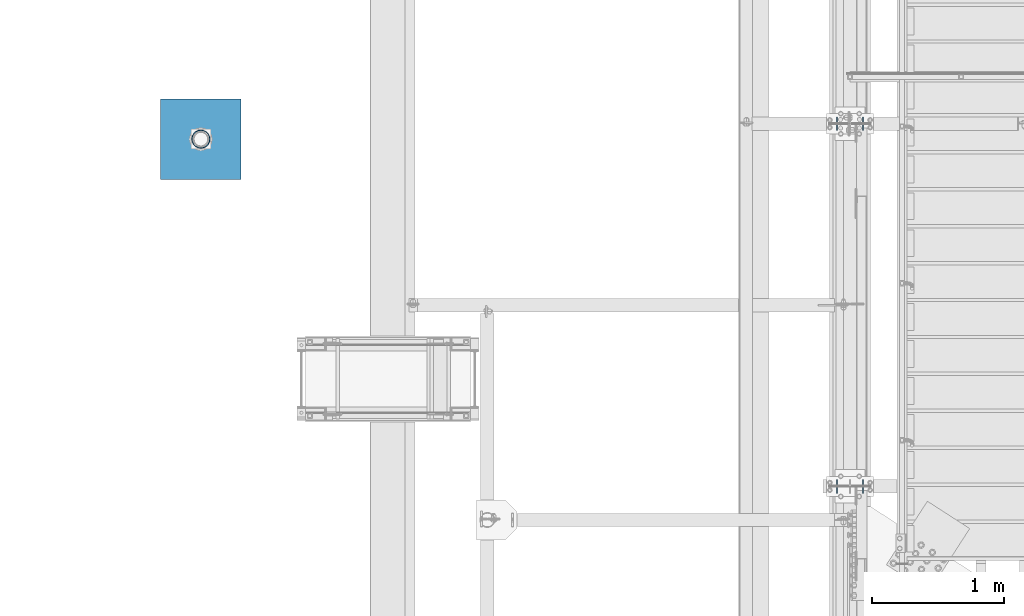
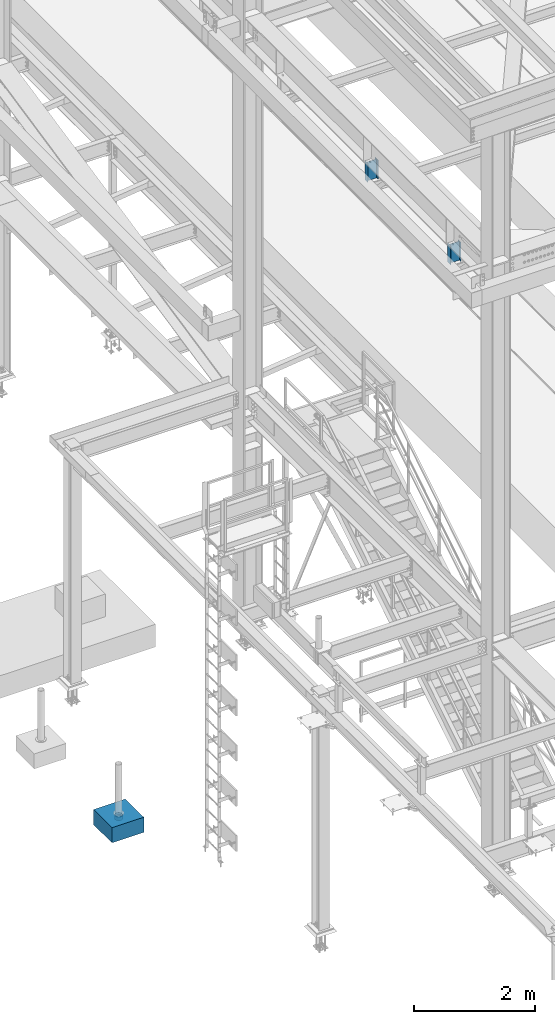
# One storey, part 1456 of 3843: 4 columns, 4 elements without a shape of their own.
"""IFC2X3 building model written with IfcOpenShell, lengths in millimetres."""

from ifc_helpers import new_model, si_unit, frame, origin_with_axes, place, context, subcontext, project, spatial, faceted_brep, material, type_object, element, aggregate, save


model = new_model("IFC2X3")

# Units and contexts
model_context = context("Model", 3, precision=1e-05, world=origin_with_axes())
body_context = subcontext(model_context, "Body", "Model", "MODEL_VIEW")
ifc_project = project(units=[si_unit("LENGTHUNIT", "METRE", prefix="MILLI"), si_unit("AREAUNIT", "SQUARE_METRE"), si_unit("VOLUMEUNIT", "CUBIC_METRE"), si_unit("MASSUNIT", "GRAM", prefix="KILO"), si_unit("TIMEUNIT", "SECOND"), si_unit("PLANEANGLEUNIT", "RADIAN"), si_unit("SOLIDANGLEUNIT", "STERADIAN"), si_unit("THERMODYNAMICTEMPERATUREUNIT", "DEGREE_CELSIUS"), si_unit("LUMINOUSINTENSITYUNIT", "LUMEN")], contexts=[model_context])

# Site, building, storey
site_placement = place(None, origin_with_axes())
site = spatial("IfcSite", under=ifc_project, at=site_placement, CompositionType="ELEMENT")
building_placement = place(site_placement, origin_with_axes())
building = spatial("IfcBuilding", under=site, at=building_placement, Name="Undefined", CompositionType="ELEMENT")
storey_placement = place(building_placement, origin_with_axes())
storey = spatial("IfcBuildingStorey", under=building, at=storey_placement, Name="Undefined", CompositionType="ELEMENT", Elevation=0.0)

# Assembly, column
assembly_1_placement = place(storey_placement, origin_with_axes())
assembly_1 = element("IfcElementAssembly", 1, at=assembly_1_placement, inside=storey, Name="PLATE", AssemblyPlace="NOTDEFINED", PredefinedType="RIGID_FRAME")
ifc_material_1 = material()
column_type_1 = type_object("IfcColumnType", Name="PIPE5SCH40", PredefinedType="NOTDEFINED")
column_1_placement = place(assembly_1_placement, frame((31665.2636373341, 29614.5098879337, 30378.4), z_axis=(-1.0, 0.0, 0.0), x_axis=(0.0, 0.0, 1.0)))
column_1 = element("IfcColumn", 2, at=column_1_placement, type_object=column_type_1, material=ifc_material_1, Name="PIPE_SLEEVE", ObjectType="PIPE5SCH40", context=body_context, shape_type="Brep", body=[
    faceted_brep([(0.0, -64.0587999999998, 0.0), (0.0, -60.9235391660477, 19.7952578392724), (76.2000000000007, -60.9235391660477, 19.7952578392724), (76.2000000000007, -64.0587999999998, 0.0), (0.0, -51.8246578392655, 37.6528179195593), (76.2000000000007, -51.8246578392655, 37.6528179195593), (0.0, -37.6528179195529, 51.8246578392718), (76.2000000000007, -37.6528179195529, 51.8246578392718), (0.0, -19.795257839266, 60.9235391660477), (76.2000000000007, -19.795257839266, 60.9235391660477), (0.0, 0.0, 64.0587999999989), (76.2000000000007, 0.0, 64.0587999999989), (0.0, 19.795257839266, 60.9235391660477), (76.2000000000007, 19.795257839266, 60.9235391660477), (0.0, 37.6528179195529, 51.8246578392718), (76.2000000000007, 37.6528179195529, 51.8246578392718), (0.0, 51.8246578392655, 37.6528179195593), (76.2000000000007, 51.8246578392655, 37.6528179195593), (0.0, 60.9235391660477, 19.7952578392724), (76.2000000000007, 60.9235391660477, 19.7952578392724), (0.0, 64.0587999999998, 0.0), (76.2000000000007, 64.0587999999998, 0.0), (0.0, 60.9235391660477, -19.7952578392724), (76.2000000000007, 60.9235391660477, -19.7952578392724), (0.0, 51.8246578392655, -37.6528179195593), (76.2000000000007, 51.8246578392655, -37.6528179195593), (0.0, 37.6528179195529, -51.8246578392718), (76.2000000000007, 37.6528179195529, -51.8246578392718), (0.0, 19.795257839266, -60.9235391660477), (76.2000000000007, 19.795257839266, -60.9235391660477), (0.0, 0.0, -64.0587999999989), (76.2000000000007, 0.0, -64.0587999999989), (0.0, -19.795257839266, -60.9235391660477), (76.2000000000007, -19.795257839266, -60.9235391660477), (0.0, -37.6528179195529, -51.8246578392718), (76.2000000000007, -37.6528179195529, -51.8246578392718), (0.0, -51.8246578392655, -37.6528179195593), (76.2000000000007, -51.8246578392655, -37.6528179195593), (0.0, -60.9235391660477, -19.7952578392724), (76.2000000000007, -60.9235391660477, -19.7952578392724), (0.0, -70.6120000000001, 0.0), (0.0, -67.1560027286332, -21.8203080068051), (76.2000000000007, -67.1560027286332, -21.8203080068051), (76.2000000000007, -70.6120000000001, 0.0), (0.0, -57.1263080068038, -41.5046922348702), (76.2000000000007, -57.1263080068038, -41.5046922348702), (0.0, -41.5046922348765, -57.126308006802), (76.2000000000007, -41.5046922348765, -57.126308006802), (0.0, -21.8203080068042, -67.1560027286323), (76.2000000000007, -21.8203080068042, -67.1560027286323), (0.0, 0.0, -70.6119999999937), (76.2000000000007, 0.0, -70.6119999999937), (0.0, 21.8203080068042, -67.1560027286323), (76.2000000000007, 21.8203080068042, -67.1560027286323), (0.0, 41.5046922348765, -57.126308006802), (76.2000000000007, 41.5046922348765, -57.126308006802), (0.0, 57.1263080068038, -41.5046922348702), (76.2000000000007, 57.1263080068038, -41.5046922348702), (0.0, 67.1560027286332, -21.8203080068051), (76.2000000000007, 67.1560027286332, -21.8203080068051), (0.0, 70.6120000000001, 0.0), (76.2000000000007, 70.6120000000001, 0.0), (0.0, 67.1560027286332, 21.8203080068051), (76.2000000000007, 67.1560027286332, 21.8203080068051), (0.0, 57.1263080068038, 41.5046922348702), (76.2000000000007, 57.1263080068038, 41.5046922348702), (0.0, 41.5046922348765, 57.126308006802), (76.2000000000007, 41.5046922348765, 57.126308006802), (0.0, 21.8203080068042, 67.1560027286323), (76.2000000000007, 21.8203080068042, 67.1560027286323), (0.0, 0.0, 70.6119999999937), (76.2000000000007, 0.0, 70.6119999999937), (0.0, -21.8203080068042, 67.1560027286323), (76.2000000000007, -21.8203080068042, 67.1560027286323), (0.0, -41.5046922348765, 57.126308006802), (76.2000000000007, -41.5046922348765, 57.126308006802), (0.0, -57.1263080068038, 41.5046922348702), (76.2000000000007, -57.1263080068038, 41.5046922348702), (0.0, -67.1560027286332, 21.8203080068051), (76.2000000000007, -67.1560027286332, 21.8203080068051)], [[[0, 1, 2, 3]], [[1, 4, 5, 2]], [[4, 6, 7, 5]], [[6, 8, 9, 7]], [[8, 10, 11, 9]], [[10, 12, 13, 11]], [[12, 14, 15, 13]], [[14, 16, 17, 15]], [[16, 18, 19, 17]], [[18, 20, 21, 19]], [[20, 22, 23, 21]], [[22, 24, 25, 23]], [[24, 26, 27, 25]], [[26, 28, 29, 27]], [[28, 30, 31, 29]], [[30, 32, 33, 31]], [[32, 34, 35, 33]], [[34, 36, 37, 35]], [[36, 38, 39, 37]], [[38, 0, 3, 39]], [[40, 41, 42, 43]], [[41, 44, 45, 42]], [[44, 46, 47, 45]], [[46, 48, 49, 47]], [[48, 50, 51, 49]], [[50, 52, 53, 51]], [[52, 54, 55, 53]], [[54, 56, 57, 55]], [[56, 58, 59, 57]], [[58, 60, 61, 59]], [[60, 62, 63, 61]], [[62, 64, 65, 63]], [[64, 66, 67, 65]], [[66, 68, 69, 67]], [[68, 70, 71, 69]], [[70, 72, 73, 71]], [[72, 74, 75, 73]], [[74, 76, 77, 75]], [[76, 78, 79, 77]], [[78, 40, 43, 79]], [[45, 47, 49, 51, 53, 55, 57, 59, 61, 63, 65, 67, 69, 71, 73, 75, 77, 79, 43, 42], [5, 7, 9, 11, 13, 15, 17, 19, 21, 23, 25, 27, 29, 31, 33, 35, 37, 39, 3, 2]], [[78, 76, 74, 72, 70, 68, 66, 64, 62, 60, 58, 56, 54, 52, 50, 48, 46, 44, 41, 40], [38, 36, 34, 32, 30, 28, 26, 24, 22, 20, 18, 16, 14, 12, 10, 8, 6, 4, 1, 0]]]),
])
aggregate(assembly_1, [column_1])

assembly_2_placement = place(storey_placement, origin_with_axes())
assembly_2 = element("IfcElementAssembly", 3, at=assembly_2_placement, inside=storey, Name="CONC_COL.", AssemblyPlace="NOTDEFINED", PredefinedType="REINFORCEMENT_UNIT")
ifc_material_2 = material(Name="CONCRETE/3000")
column_type_2 = type_object("IfcColumnType", PredefinedType="NOTDEFINED")
column_2_placement = place(assembly_2_placement, frame((31665.2636373341, 29614.5098879337, 30175.2), z_axis=(-1.0, 0.0, 0.0), x_axis=(0.0, 0.0, 1.0)))
column_2 = element("IfcColumn", 4, at=column_2_placement, type_object=column_type_2, material=ifc_material_2, Name="CONC_COL.", context=body_context, shape_type="Brep", body=[
    faceted_brep([(0.0, 304.8, -304.800000000003), (0.0, 304.8, 304.800000000003), (304.799999999999, 304.8, 304.800000000003), (304.799999999999, 304.8, -304.800000000003), (0.0, -304.8, 304.800000000003), (304.799999999999, -304.8, 304.800000000003), (0.0, -304.8, -304.800000000003), (304.799999999999, -304.8, -304.800000000003)], [[[0, 1, 2, 3]], [[1, 4, 5, 2]], [[4, 6, 7, 5]], [[6, 0, 3, 7]], [[5, 7, 3, 2]], [[6, 4, 1, 0]]]),
])
aggregate(assembly_2, [column_2])

assembly_3_placement = place(storey_placement, origin_with_axes())
assembly_3 = element("IfcElementAssembly", 5, at=assembly_3_placement, inside=storey, Name="POST", AssemblyPlace="NOTDEFINED", PredefinedType="RIGID_FRAME")
ifc_material_3 = material(Name="STEEL/A992")
column_type_3 = type_object("IfcColumnType", Name="W8X13", PredefinedType="NOTDEFINED")
column_3_placement = place(assembly_3_placement, frame((36576.0000030518, 26987.5, 41503.6), z_axis=(-1.0, 0.0, 0.0), x_axis=(0.0, 0.0, 1.0)))
column_3 = element("IfcColumn", 6, at=column_3_placement, type_object=column_type_3, material=ifc_material_3, Name="POST", ObjectType="W8X13", context=body_context, shape_type="Brep", body=[
    faceted_brep([(19.0499994920028, 50.7999999999993, -101.600000000035), (19.0499995237551, 50.7999999999993, -95.2500000000364), (403.224999428487, 50.7999999999993, -95.2499999989232), (403.22499939039, 50.7999999999993, -101.599999998929), (19.0499995237551, 3.17499999999927, -95.2500000000364), (403.224999428487, 3.17499999999927, -95.2499999989232), (19.0500004762507, 3.17499999999927, 95.2499999999636), (403.225000571489, 3.17499999999927, 95.2500000010768), (19.0500004762507, 50.7999999999993, 95.2499999999636), (403.225000571489, 50.7999999999993, 95.2500000010768), (19.050000508003, 50.7999999999993, 101.599999999969), (403.225000609593, 50.7999999999993, 101.600000001075), (19.050000508003, -50.7999999999993, 101.599999999969), (403.225000609593, -50.7999999999993, 101.600000001075), (19.0500004762507, -50.7999999999993, 95.2499999999636), (403.225000571489, -50.7999999999993, 95.2500000010768), (19.0500004762507, -3.17499999999927, 95.2499999999636), (403.225000571489, -3.17499999999927, 95.2500000010768), (19.0499995237551, -3.17499999999927, -95.2500000000364), (403.224999428487, -3.17499999999927, -95.2499999989232), (19.0499995237551, -50.7999999999993, -95.2500000000364), (403.224999428487, -50.7999999999993, -95.2499999989232), (19.0499994920028, -50.7999999999993, -101.600000000035), (403.22499939039, -50.7999999999993, -101.599999998929)], [[[0, 1, 2, 3]], [[1, 4, 5, 2]], [[4, 6, 7, 5]], [[6, 8, 9, 7]], [[8, 10, 11, 9]], [[10, 12, 13, 11]], [[12, 14, 15, 13]], [[14, 16, 17, 15]], [[16, 18, 19, 17]], [[18, 20, 21, 19]], [[20, 22, 23, 21]], [[22, 0, 3, 23]], [[5, 7, 9, 11, 13, 15, 17, 19, 21, 23, 3, 2]], [[22, 20, 18, 16, 14, 12, 10, 8, 6, 4, 1, 0]]]),
])
aggregate(assembly_3, [column_3])

assembly_4_placement = place(storey_placement, origin_with_axes())
assembly_4 = element("IfcElementAssembly", 7, at=assembly_4_placement, inside=storey, Name="POST", AssemblyPlace="NOTDEFINED", PredefinedType="RIGID_FRAME")
column_4_placement = place(assembly_4_placement, frame((36576.0000030518, 29730.7, 41503.6), z_axis=(-1.0, 0.0, 0.0), x_axis=(0.0, 0.0, 1.0)))
column_4 = element("IfcColumn", 8, at=column_4_placement, type_object=column_type_3, material=ifc_material_3, Name="POST", ObjectType="W8X13", context=body_context, shape_type="Brep", body=[
    faceted_brep([(19.0499994920028, 50.7999999999993, -101.600000000035), (19.0499995237551, 50.7999999999993, -95.2500000000364), (403.224999428487, 50.7999999999993, -95.2499999989232), (403.22499939039, 50.7999999999993, -101.599999998929), (19.0499995237551, 3.17499999999927, -95.2500000000364), (403.224999428487, 3.17499999999927, -95.2499999989232), (19.0500004762507, 3.17499999999927, 95.2499999999636), (403.225000571489, 3.17499999999927, 95.2500000010768), (19.0500004762507, 50.7999999999993, 95.2499999999636), (403.225000571489, 50.7999999999993, 95.2500000010768), (19.050000508003, 50.7999999999993, 101.599999999969), (403.225000609593, 50.7999999999993, 101.600000001075), (19.050000508003, -50.7999999999993, 101.599999999969), (403.225000609593, -50.7999999999993, 101.600000001075), (19.0500004762507, -50.7999999999993, 95.2499999999636), (403.225000571489, -50.7999999999993, 95.2500000010768), (19.0500004762507, -3.17499999999927, 95.2499999999636), (403.225000571489, -3.17499999999927, 95.2500000010768), (19.0499995237551, -3.17499999999927, -95.2500000000364), (403.224999428487, -3.17499999999927, -95.2499999989232), (19.0499995237551, -50.7999999999993, -95.2500000000364), (403.224999428487, -50.7999999999993, -95.2499999989232), (19.0499994920028, -50.7999999999993, -101.600000000035), (403.22499939039, -50.7999999999993, -101.599999998929)], [[[0, 1, 2, 3]], [[1, 4, 5, 2]], [[4, 6, 7, 5]], [[6, 8, 9, 7]], [[8, 10, 11, 9]], [[10, 12, 13, 11]], [[12, 14, 15, 13]], [[14, 16, 17, 15]], [[16, 18, 19, 17]], [[18, 20, 21, 19]], [[20, 22, 23, 21]], [[22, 0, 3, 23]], [[5, 7, 9, 11, 13, 15, 17, 19, 21, 23, 3, 2]], [[22, 20, 18, 16, 14, 12, 10, 8, 6, 4, 1, 0]]]),
])
aggregate(assembly_4, [column_4])

save(model, "model.ifc")
